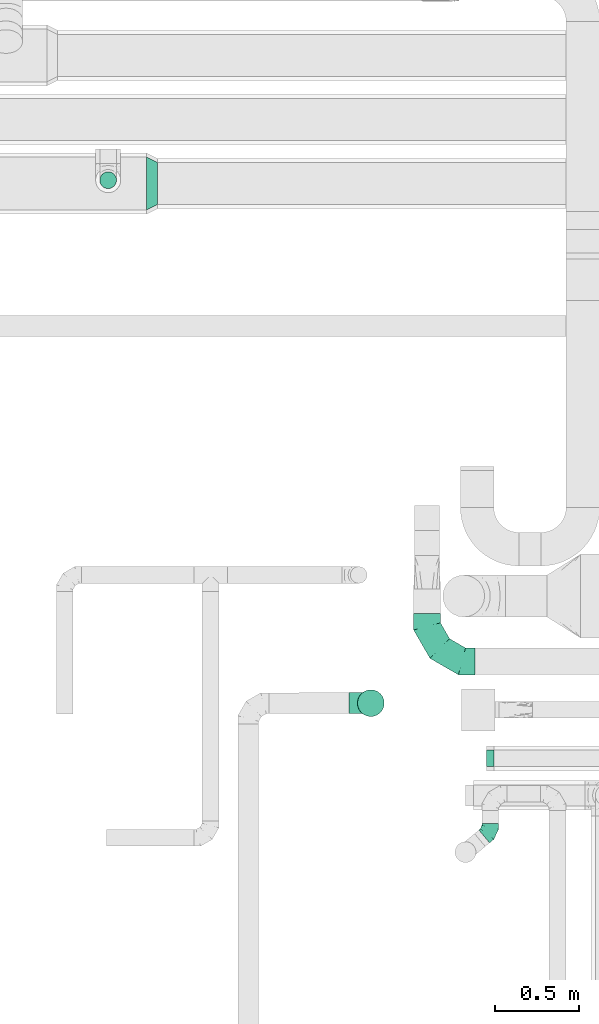
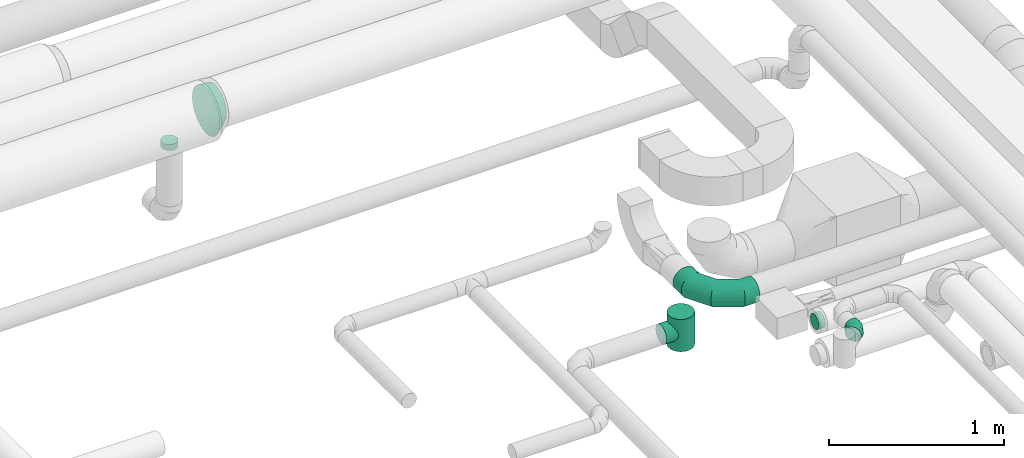
# One storey, part 90 of 92: 6 flow fittings.
"""IFC2X3 building model written with IfcOpenShell, lengths in millimetres."""

import ifcopenshell
import ifcopenshell.guid

model = None  # the IFC model being written
_history = None  # IfcOwnerHistory: only IFC2X3 demands one
_inside = {}  # id of a spatial element -> (the spatial element, [elements in it])
_under = {}  # id of a project, library or spatial element -> (it, [spatial elements below it])
_declared = {}  # id of a project -> (the project, [libraries it declares])
_typed = {}  # id of a type object -> (the type object, [elements of that type])
_made_of = {}  # id of a material, layer set ... -> (it, [elements and type objects made of it])


def new_model(schema):
    """Start an empty IFC model of exactly this schema.

    Asked for "IFC4X3", IfcOpenShell would pick the latest addendum, in which some entities
    have other attributes; the version numbers below select the first issue.
    IFC2X3 requires an IfcOwnerHistory on every rooted entity: one is made here for all.
    """
    global model, _history
    if schema == "IFC4X3":
        model = ifcopenshell.file(schema_version=(4, 3, 0, 0))
    else:
        model = ifcopenshell.file(schema=schema)
    _inside.clear()
    _under.clear()
    _declared.clear()
    _typed.clear()
    _made_of.clear()
    _history = None
    if model.schema == "IFC2X3":
        org = make("IfcOrganization", Name="unknown")
        user = make(
            "IfcPersonAndOrganization",
            ThePerson=make("IfcPerson", FamilyName="unknown"),
            TheOrganization=org,
        )
        app = make(
            "IfcApplication",
            ApplicationDeveloper=org,
            Version="unknown",
            ApplicationFullName="unknown",
            ApplicationIdentifier="unknown",
        )
        _history = make(
            "IfcOwnerHistory",
            OwningUser=user,
            OwningApplication=app,
            ChangeAction="ADDED",
            CreationDate=0,
        )
    return model


def make(cls, **values):
    """One entity of the class cls with the attributes given. An attribute that is None is left unset."""
    return model.create_entity(
        cls, **{name: value for name, value in values.items() if value is not None}
    )


def entity(cls, *values):
    """Any entity or typed value of the class cls, its attributes in the order of the schema. None: left unset."""
    e = model.create_entity(cls)
    for i, value in enumerate(values):
        if value is not None:
            e[i] = value
    return e


def rooted(cls, **values):
    """An entity with a GlobalId (a new one), such as an element, a storey or a relation."""
    return make(cls, GlobalId=ifcopenshell.guid.new(), OwnerHistory=_history, **values)


def si_unit(unit_type, name, prefix=None):
    """IfcSIUnit, for example si_unit("LENGTHUNIT", "METRE", prefix="MILLI")."""
    return make("IfcSIUnit", UnitType=unit_type, Prefix=prefix, Name=name)


def converted_unit(unit_type, name, factor, base, dimensions=None, offset=None):
    """IfcConversionBasedUnit, such as the inch: factor (a typed value) times the base unit."""
    return make(
        "IfcConversionBasedUnit"
        if offset is None
        else "IfcConversionBasedUnitWithOffset",
        ConversionOffset=offset,
        Dimensions=None
        if dimensions is None
        else entity("IfcDimensionalExponents", *dimensions),
        UnitType=unit_type,
        Name=name,
        ConversionFactor=make(
            "IfcMeasureWithUnit", ValueComponent=factor, UnitComponent=base
        ),
    )


def derived_unit(unit_type, elements):
    """IfcDerivedUnit: a product of units, each with its exponent."""
    return make(
        "IfcDerivedUnit",
        Elements=[
            make("IfcDerivedUnitElement", Unit=unit, Exponent=power)
            for unit, power in elements
        ],
        UnitType=unit_type,
    )


def assignment(units):
    """IfcUnitAssignment: the units of a project."""
    return None if units is None else make("IfcUnitAssignment", Units=units)


def point(xyz):
    """IfcCartesianPoint."""
    return None if xyz is None else make("IfcCartesianPoint", Coordinates=xyz)


def direction(xyz):
    """IfcDirection."""
    return None if xyz is None else make("IfcDirection", DirectionRatios=xyz)


def frame(location, z_axis=None, x_axis=None):
    """IfcAxis2Placement3D, a coordinate frame: its origin and axes. An axis left out is left unset."""
    return make(
        "IfcAxis2Placement3D",
        Location=point(location),
        Axis=direction(z_axis),
        RefDirection=direction(x_axis),
    )


def origin():
    """The frame at (0, 0, 0) with its axes left unset."""
    return frame((0.0, 0.0, 0.0))


def place(relative_to, where):
    """IfcLocalPlacement: puts the frame where relative to a parent placement (None: the world)."""
    return make(
        "IfcLocalPlacement", PlacementRelTo=relative_to, RelativePlacement=where
    )


def context(
    kind, dimensions, precision=None, world=None, true_north=None, identifier=None
):
    """IfcGeometricRepresentationContext, for example the 3D "Model" context."""
    return make(
        "IfcGeometricRepresentationContext",
        ContextIdentifier=identifier,
        ContextType=kind,
        CoordinateSpaceDimension=dimensions,
        Precision=precision,
        WorldCoordinateSystem=world,
        TrueNorth=true_north,
    )


def subcontext(parent, identifier, kind, view, scale=None):
    """IfcGeometricRepresentationSubContext, for example "Body" below "Model"."""
    return make(
        "IfcGeometricRepresentationSubContext",
        ContextIdentifier=identifier,
        ContextType=kind,
        ParentContext=parent,
        TargetScale=scale,
        TargetView=view,
    )


def project(units=None, contexts=None):
    """IfcProject with its units and contexts."""
    return rooted(
        "IfcProject",
        Name="project",
        RepresentationContexts=contexts,
        UnitsInContext=assignment(units),
    )


def spatial(cls, under=None, at=None, **own):
    """A site, building, storey or space (cls), placed at a placement, below another one or the project."""
    s = rooted(cls, ObjectPlacement=at, **own)
    if under is not None:
        _under.setdefault(under.id(), (under, []))[1].append(s)
    return s


def faces_of(points, faces, orient=None, outer=None):
    """IfcFace entities. A face is a list of loops; a loop is a list of indices into points, from 0.

    orient and outer hold one flag for each loop. By default every Orientation is true, the
    first loop of a face is its IfcFaceOuterBound and the others are IfcFaceBound.
    """
    made = []
    for i, loops in enumerate(faces):
        bounds = []
        for j, loop in enumerate(loops):
            is_outer = j == 0 if outer is None else outer[i][j]
            bounds.append(
                make(
                    "IfcFaceOuterBound" if is_outer else "IfcFaceBound",
                    Bound=make("IfcPolyLoop", Polygon=[points[k] for k in loop]),
                    Orientation=True if orient is None else orient[i][j],
                )
            )
        made.append(make("IfcFace", Bounds=bounds))
    return made


def faceted_brep(points, faces, orient=None, outer=None, voids=None):
    """IfcFacetedBrep: a solid bounded by flat faces; with voids (closed shells), ...WithVoids."""
    shared = [point(p) for p in points]
    hull = make("IfcClosedShell", CfsFaces=faces_of(shared, faces, orient, outer))
    if voids is None:
        return make("IfcFacetedBrep", Outer=hull)
    return make(
        "IfcFacetedBrepWithVoids",
        Outer=hull,
        Voids=[
            make(cls, CfsFaces=faces_of(shared, fs, o, b)) for cls, fs, o, b in voids
        ],
    )


def shape(context_of_items, identifier, shape_type, items):
    """IfcShapeRepresentation: the items that make up one representation, for example the "Body"."""
    return make(
        "IfcShapeRepresentation",
        ContextOfItems=context_of_items,
        RepresentationIdentifier=identifier,
        RepresentationType=shape_type,
        Items=items,
    )


def source(mapping_origin, context_of_items, identifier, shape_type, items):
    """IfcRepresentationMap: a shape defined once, which mapped items show again and again."""
    return make(
        "IfcRepresentationMap",
        MappingOrigin=mapping_origin,
        MappedRepresentation=shape(context_of_items, identifier, shape_type, items),
    )


def transform(
    local_origin,
    x_axis=None,
    y_axis=None,
    z_axis=None,
    scale=None,
    scale2=None,
    scale3=None,
    uniform=True,
):
    """IfcCartesianTransformationOperator3D, or its non-uniform kind. x_axis, y_axis, z_axis: its Axis1, 2, 3."""
    if uniform:
        return make(
            "IfcCartesianTransformationOperator3D",
            Axis1=direction(x_axis),
            Axis2=direction(y_axis),
            LocalOrigin=point(local_origin),
            Scale=scale,
            Axis3=direction(z_axis),
        )
    return make(
        "IfcCartesianTransformationOperator3DnonUniform",
        Axis1=direction(x_axis),
        Axis2=direction(y_axis),
        LocalOrigin=point(local_origin),
        Scale=scale,
        Axis3=direction(z_axis),
        Scale2=scale2,
        Scale3=scale3,
    )


def mapped(mapping_source, mapping_target):
    """IfcMappedItem: shows the shape of a source again, moved by a transform."""
    return make(
        "IfcMappedItem", MappingSource=mapping_source, MappingTarget=mapping_target
    )


def material(Name=None, Category=None):
    """IfcMaterial."""
    return make("IfcMaterial", Name=Name, Category=Category)


def made_of(thing, what):
    """Note that an element or type object is made of a material, layer set ...; save() writes the relation."""
    if what is not None:
        _made_of.setdefault(what.id(), (what, []))[1].append(thing)
    return thing


def type_object(cls, material=None, **own):
    """A type object (cls), such as IfcWallType, which elements share."""
    return made_of(rooted(cls, **own), material)


def type_shapes(of_type, sources):
    """Give a type object the sources (RepresentationMaps) that its elements show as mapped items."""
    of_type.RepresentationMaps = sources


def element(
    cls,
    number,
    at=None,
    inside=None,
    cuts=None,
    type_object=None,
    material=None,
    context=None,
    identifier="Body",
    shape_type=None,
    held_by="IfcProductDefinitionShape",
    body=None,
    shapes=None,
    **own,
):
    """One element of the class cls, such as IfcWall. Its Tag is "e" and its number.

    at: its placement. inside: the storey or other place that contains it. cuts: it is an
    opening in that element (IfcRelVoidsElement). A single representation is given by context,
    identifier, shape_type and body (its items); several are given by shapes. held_by: the class
    of the entity that holds the representations. save() writes the other relations.
    """
    e = rooted(cls, Tag="e%d" % number, ObjectPlacement=at, **own)
    if body is not None:
        shapes = [shape(context, identifier, shape_type, body)]
    if shapes is not None:
        e.Representation = make(held_by, Representations=shapes)
    if inside is not None:
        _inside.setdefault(inside.id(), (inside, []))[1].append(e)
    if cuts is not None:
        rooted(
            "IfcRelVoidsElement", RelatingBuildingElement=cuts, RelatedOpeningElement=e
        )
    if type_object is not None:
        _typed.setdefault(type_object.id(), (type_object, []))[1].append(e)
    return made_of(e, material)


def aggregate(whole, parts):
    """IfcRelAggregates: a whole, such as a stair, and the parts it consists of."""
    return rooted("IfcRelAggregates", RelatingObject=whole, RelatedObjects=parts)


def save(model, path):
    """Write the relations noted so far, then the file.

    IfcRelAggregates (storeys below a building ...), IfcRelContainedInSpatialStructure (elements
    in a storey), IfcRelDefinesByType, IfcRelAssociatesMaterial and IfcRelDeclares: one each for
    every whole, place, type object, material and project.
    """
    for whole, parts in _under.values():
        aggregate(whole, parts)
    for where, things in _inside.values():
        rooted(
            "IfcRelContainedInSpatialStructure",
            RelatedElements=things,
            RelatingStructure=where,
        )
    for kind, things in _typed.values():
        rooted("IfcRelDefinesByType", RelatedObjects=things, RelatingType=kind)
    for what, things in _made_of.values():
        rooted("IfcRelAssociatesMaterial", RelatedObjects=things, RelatingMaterial=what)
    for by, libraries in _declared.values():
        rooted("IfcRelDeclares", RelatingContext=by, RelatedDefinitions=libraries)
    model.write(path)


model = new_model("IFC2X3")

# Units and contexts
model_context = context("Model", 3, precision=0.01, world=origin(), true_north=direction((6.12303176911189e-17, 1.0)))
body_context = subcontext(model_context, "Body", "Model", "MODEL_VIEW")
ifc_project = project(units=[si_unit("LENGTHUNIT", "METRE", prefix="MILLI"), si_unit("AREAUNIT", "SQUARE_METRE"), si_unit("VOLUMEUNIT", "CUBIC_METRE"), converted_unit("PLANEANGLEUNIT", "DEGREE", entity("IfcRatioMeasure", 0.0174532925199433), si_unit("PLANEANGLEUNIT", "RADIAN"), dimensions=[0, 0, 0, 0, 0, 0, 0]), si_unit("MASSUNIT", "GRAM", prefix="KILO"), derived_unit("MASSDENSITYUNIT", [(si_unit("MASSUNIT", "GRAM", prefix="KILO"), 1), (si_unit("LENGTHUNIT", "METRE"), -3)]), derived_unit("MOMENTOFINERTIAUNIT", [(si_unit("LENGTHUNIT", "METRE"), 4)]), si_unit("TIMEUNIT", "SECOND"), si_unit("FREQUENCYUNIT", "HERTZ"), si_unit("THERMODYNAMICTEMPERATUREUNIT", "DEGREE_CELSIUS"), derived_unit("THERMALTRANSMITTANCEUNIT", [(si_unit("MASSUNIT", "GRAM", prefix="KILO"), 1), (si_unit("THERMODYNAMICTEMPERATUREUNIT", "KELVIN"), -1), (si_unit("TIMEUNIT", "SECOND"), -3)]), derived_unit("VOLUMETRICFLOWRATEUNIT", [(si_unit("LENGTHUNIT", "METRE"), 3), (si_unit("TIMEUNIT", "SECOND"), -1)]), derived_unit("MASSFLOWRATEUNIT", [(si_unit("MASSUNIT", "GRAM", prefix="KILO"), 1), (si_unit("TIMEUNIT", "SECOND"), -1)]), derived_unit("ROTATIONALFREQUENCYUNIT", [(si_unit("TIMEUNIT", "SECOND"), -1)]), si_unit("ELECTRICCURRENTUNIT", "AMPERE"), si_unit("ELECTRICVOLTAGEUNIT", "VOLT"), si_unit("POWERUNIT", "WATT"), si_unit("FORCEUNIT", "NEWTON", prefix="KILO"), si_unit("ILLUMINANCEUNIT", "LUX"), si_unit("LUMINOUSFLUXUNIT", "LUMEN"), si_unit("LUMINOUSINTENSITYUNIT", "CANDELA"), derived_unit("USERDEFINED", [(si_unit("MASSUNIT", "GRAM", prefix="KILO"), -1), (si_unit("LENGTHUNIT", "METRE"), -2), (si_unit("TIMEUNIT", "SECOND"), 3), (si_unit("LUMINOUSFLUXUNIT", "LUMEN"), 1)]), derived_unit("LINEARVELOCITYUNIT", [(si_unit("LENGTHUNIT", "METRE"), 1), (si_unit("TIMEUNIT", "SECOND"), -1)]), si_unit("PRESSUREUNIT", "PASCAL"), derived_unit("USERDEFINED", [(si_unit("LENGTHUNIT", "METRE"), -2), (si_unit("MASSUNIT", "GRAM", prefix="KILO"), 1), (si_unit("TIMEUNIT", "SECOND"), -2)]), derived_unit("LINEARFORCEUNIT", [(si_unit("MASSUNIT", "GRAM", prefix="KILO"), 1), (si_unit("LENGTHUNIT", "METRE"), 1), (si_unit("TIMEUNIT", "SECOND"), -2), (si_unit("LENGTHUNIT", "METRE"), -1)]), derived_unit("PLANARFORCEUNIT", [(si_unit("MASSUNIT", "GRAM", prefix="KILO"), 1), (si_unit("LENGTHUNIT", "METRE"), 1), (si_unit("TIMEUNIT", "SECOND"), -2), (si_unit("LENGTHUNIT", "METRE"), -2)])], contexts=[model_context])

# Site, building, storey
site_placement = place(None, origin())
site = spatial("IfcSite", under=ifc_project, at=site_placement, CompositionType="ELEMENT")
building_placement = place(site_placement, origin())
building = spatial("IfcBuilding", under=site, at=building_placement, CompositionType="ELEMENT")
storey_placement = place(building_placement, frame((0.0, 0.0, 4200.0)))
storey = spatial("IfcBuildingStorey", under=building, at=storey_placement, CompositionType="ELEMENT", Elevation=4200.0)

# Flow fittings
ifc_material = material()
duct_fitting_type_1 = type_object("IfcDuctFittingType", PredefinedType="NOTDEFINED", material=ifc_material)
shared_shape_1 = source(origin(), body_context, "Body", "Brep", [
    faceted_brep([(16.18, -130.0, -60.37), (31.25, -130.0, -54.13), (44.19, -130.0, -44.19), (54.13, -130.0, -31.25), (60.37, -130.0, -16.18), (62.5, -130.0, 0.0), (60.37, -130.0, 16.18), (54.13, -130.0, 31.25), (44.19, -130.0, 44.19), (31.25, -130.0, 54.13), (16.18, -130.0, 60.37), (0.0, -130.0, 62.5), (-16.18, -130.0, 60.37), (-31.25, -130.0, 54.13), (-44.19, -130.0, 44.19), (-54.13, -130.0, 31.25), (-60.37, -130.0, 16.18), (-62.5, -130.0, 0.0), (-60.37, -130.0, -16.18), (-54.13, -130.0, -31.25), (-44.19, -130.0, -44.19), (-31.25, -130.0, -54.13), (-16.18, -130.0, -60.37), (0.0, -130.0, -62.5), (12.74, -51.54, 61.19), (24.44, -55.6, 57.52), (34.82, -60.88, 51.9), (43.86, -66.46, 44.53), (0.0, -49.94, 62.5), (51.46, -71.71, 35.47), (57.36, -76.05, 24.81), (61.17, -78.97, 12.81), (62.5, -80.0, 0.0), (61.17, -78.97, -12.81), (51.46, -71.71, -35.47), (57.36, -76.05, -24.81), (43.86, -66.46, -44.52), (34.82, -60.88, -51.9), (24.44, -55.6, -57.52), (12.73, -51.53, -61.19), (0.0, -49.94, -62.5), (-12.74, -51.54, -61.19), (-24.44, -55.6, -57.52), (-34.82, -60.88, -51.9), (-43.86, -66.46, -44.53), (-51.46, -71.71, -35.47), (-57.36, -76.05, -24.81), (-61.17, -78.97, -12.81), (-62.5, -80.0, 0.0), (-61.17, -78.97, 12.81), (-57.36, -76.05, 24.81), (-51.46, -71.71, 35.47), (-43.86, -66.46, 44.53), (-34.82, -60.88, 51.9), (-24.44, -55.6, 57.52), (-12.74, -51.54, 61.19), (-112.5, 0.0, -80.0), (-112.5, -20.71, -77.27), (-112.5, -40.0, -69.28), (-112.5, -56.57, -56.57), (-112.5, -62.93, -48.28), (-112.5, -69.28, -40.0), (-112.5, -73.28, -30.35), (-112.5, -77.27, -20.71), (-112.5, -78.64, -10.35), (-112.5, -80.0, 0.0), (-112.5, -78.64, 10.35), (-112.5, -77.27, 20.71), (-112.5, -73.28, 30.35), (-112.5, -69.28, 40.0), (-112.5, -62.93, 48.28), (-112.5, -56.57, 56.57), (-112.5, -40.0, 69.28), (-112.5, -20.71, 77.27), (-112.5, 0.0, 80.0), (-112.5, 20.71, 77.27), (-112.5, 40.0, 69.28), (-112.5, 56.57, 56.57), (-112.5, 69.28, 40.0), (-112.5, 77.27, 20.71), (-112.5, 80.0, 0.0), (-112.5, 77.27, -20.71), (-112.5, 69.28, -40.0), (-112.5, 56.57, -56.57), (-112.5, 40.0, -69.28), (-112.5, 20.71, -77.27), (112.5, 20.71, -77.27), (112.5, 40.0, -69.28), (112.5, 56.57, -56.57), (112.5, 69.28, -40.0), (112.5, 77.27, -20.71), (112.5, 80.0, 0.0), (112.5, 77.27, 20.71), (112.5, 69.28, 40.0), (112.5, 56.57, 56.57), (112.5, 40.0, 69.28), (112.5, 20.71, 77.27), (112.5, 0.0, 80.0), (112.5, -20.71, 77.27), (112.5, -40.0, 69.28), (112.5, -56.57, 56.57), (112.5, -62.93, 48.28), (112.5, -69.28, 40.0), (112.5, -73.28, 30.35), (112.5, -77.27, 20.71), (112.5, -78.64, 10.35), (112.5, -80.0, 0.0), (112.5, -78.64, -10.35), (112.5, -77.27, -20.71), (112.5, -73.28, -30.35), (112.5, -69.28, -40.0), (112.5, -62.93, -48.28), (112.5, -56.57, -56.57), (112.5, -40.0, -69.28), (112.5, -20.71, -77.27), (112.5, 0.0, -80.0)], [[[0, 1, 2, 3, 4, 5, 6, 7, 8, 9, 10, 11, 12, 13, 14, 15, 16, 17, 18, 19, 20, 21, 22, 23]], [[24, 11, 10]], [[10, 9, 25]], [[8, 26, 9]], [[8, 27, 26]], [[28, 11, 24]], [[24, 10, 25]], [[9, 26, 25]], [[29, 8, 7]], [[30, 7, 6]], [[31, 6, 5]], [[30, 29, 7]], [[32, 31, 5]], [[30, 6, 31]], [[8, 29, 27]], [[5, 4, 33]], [[3, 2, 34]], [[4, 3, 35]], [[33, 32, 5]], [[34, 35, 3]], [[33, 4, 35]], [[2, 36, 34]], [[36, 2, 37]], [[37, 2, 1]], [[38, 1, 0]], [[39, 0, 23]], [[37, 1, 38]], [[39, 38, 0]], [[40, 39, 23]], [[41, 23, 22]], [[22, 21, 42]], [[20, 43, 21]], [[20, 44, 43]], [[40, 23, 41]], [[41, 22, 42]], [[21, 43, 42]], [[45, 20, 19]], [[46, 19, 18]], [[47, 18, 17]], [[46, 45, 19]], [[48, 47, 17]], [[46, 18, 47]], [[20, 45, 44]], [[49, 17, 16]], [[50, 16, 15]], [[51, 15, 14]], [[49, 48, 17]], [[51, 50, 15]], [[49, 16, 50]], [[14, 52, 51]], [[52, 14, 53]], [[53, 14, 13]], [[54, 13, 12]], [[55, 12, 11]], [[53, 13, 54]], [[55, 54, 12]], [[28, 55, 11]], [[56, 57, 58, 59, 60, 61, 62, 63, 64, 65, 66, 67, 68, 69, 70, 71, 72, 73, 74, 75, 76, 77, 78, 79, 80, 81, 82, 83, 84, 85]], [[86, 87, 88, 89, 90, 91, 92, 93, 94, 95, 96, 97, 98, 99, 100, 101, 102, 103, 104, 105, 106, 107, 108, 109, 110, 111, 112, 113, 114, 115]], [[75, 74, 97, 96]], [[76, 75, 96, 95]], [[95, 94, 77, 76]], [[79, 78, 93, 92]], [[80, 79, 92, 91]], [[94, 93, 78, 77]], [[81, 80, 91, 90]], [[82, 81, 90, 89]], [[89, 88, 83, 82]], [[85, 84, 87, 86]], [[56, 85, 86, 115]], [[88, 87, 84, 83]], [[114, 57, 56, 115]], [[113, 58, 57, 114]], [[112, 37, 38]], [[112, 111, 37]], [[46, 63, 62]], [[38, 39, 112]], [[34, 109, 35]], [[112, 39, 113]], [[39, 40, 113]], [[113, 40, 58]], [[40, 41, 58]], [[41, 42, 59]], [[48, 64, 47]], [[43, 44, 60]], [[43, 59, 42]], [[44, 61, 60]], [[41, 59, 58]], [[37, 111, 36]], [[33, 108, 107]], [[109, 34, 110]], [[35, 109, 108]], [[34, 36, 110]], [[110, 36, 111]], [[106, 32, 107]], [[48, 65, 64]], [[33, 107, 32]], [[108, 33, 35]], [[44, 45, 61]], [[45, 62, 61]], [[62, 45, 46]], [[60, 59, 43]], [[64, 63, 47]], [[47, 63, 46]], [[106, 105, 32]], [[65, 48, 66]], [[31, 105, 104]], [[102, 29, 103]], [[30, 103, 29]], [[104, 30, 31]], [[49, 66, 48]], [[49, 50, 67]], [[51, 52, 69]], [[50, 68, 67]], [[68, 51, 69]], [[52, 70, 69]], [[29, 102, 27]], [[101, 26, 27]], [[26, 101, 100]], [[27, 102, 101]], [[25, 26, 100]], [[100, 24, 25]], [[32, 105, 31]], [[73, 72, 99, 98]], [[28, 24, 99]], [[99, 24, 100]], [[98, 97, 74, 73]], [[51, 68, 50]], [[54, 55, 71]], [[49, 67, 66]], [[70, 53, 71]], [[71, 53, 54]], [[55, 72, 71]], [[30, 104, 103]], [[28, 72, 55]], [[28, 99, 72]], [[53, 70, 52]]]),
])
type_shapes(duct_fitting_type_1, [shared_shape_1])
flow_fitting_1_placement = place(storey_placement, frame((58915.63, 11854.23, 3150.0), z_axis=(0.0, -1.0, 0.0), x_axis=(0.0, 0.0, -1.0)))
element("IfcFlowFitting", 1, at=flow_fitting_1_placement, inside=storey, type_object=duct_fitting_type_1, material=ifc_material, context=body_context, shape_type="MappedRepresentation", body=[
    mapped(shared_shape_1, transform((0.0, 0.0, 0.0), scale=1.0)),
])
duct_fitting_type_2 = type_object("IfcDuctFittingType", PredefinedType="NOTDEFINED", material=ifc_material)
shared_shape_2 = source(origin(), body_context, "Body", "Brep", [
    faceted_brep([(-46.66, 0.0, -50.0), (-46.66, -12.94, -48.3), (-46.66, -25.0, -43.3), (-46.66, -35.36, -35.36), (-46.66, -43.3, -25.0), (-46.66, -48.3, -12.94), (-46.66, -50.0, 0.0), (-46.66, -48.3, 12.94), (-46.66, -43.3, 25.0), (-46.66, -35.36, 35.36), (-46.66, -25.0, 43.3), (-46.66, -12.94, 48.3), (-46.66, 0.0, 50.0), (-46.66, 12.94, 48.3), (-46.66, 25.0, 43.3), (-46.66, 35.36, 35.36), (-46.66, 43.3, 25.0), (-46.66, 48.3, 12.94), (-46.66, 50.0, 0.0), (-46.66, 48.3, -12.94), (-46.66, 43.3, -25.0), (-46.66, 35.36, -35.36), (-46.66, 25.0, -43.3), (-46.66, 12.94, -48.3), (-27.35, 12.94, 48.3), (-30.02, 25.0, 43.3), (-24.48, 0.0, 50.0), (-32.32, 35.36, 35.36), (-35.19, 48.3, 12.94), (-35.57, 50.0, 0.0), (-34.08, 43.3, 25.0), (-34.08, 43.3, -25.0), (-32.32, 35.36, -35.36), (-35.19, 48.3, -12.94), (-27.35, 12.94, -48.3), (-24.48, 0.0, -50.0), (-30.02, 25.0, -43.3), (-21.61, -12.94, -48.3), (-18.93, -25.0, -43.3), (-16.63, -35.36, -35.36), (-14.87, -43.3, -25.0), (-13.76, -48.3, -12.94), (-13.39, -50.0, 0.0), (-13.76, -48.3, 12.94), (-14.87, -43.3, 25.0), (-16.63, -35.36, 35.36), (-18.93, -25.0, 43.3), (-21.61, -12.94, 48.3), (7.65, 29.27, 48.3), (0.13, 39.07, 43.3), (15.72, 18.76, 50.0), (-6.33, 47.48, 35.36), (-11.29, 53.94, 25.0), (-14.4, 57.99, 12.94), (-15.47, 59.38, 0.0), (-14.4, 57.99, -12.94), (-11.29, 53.94, -25.0), (-6.33, 47.48, -35.36), (7.65, 29.27, -48.3), (15.72, 18.76, -50.0), (0.13, 39.07, -43.3), (23.8, 8.24, -48.3), (31.32, -1.55, -43.3), (37.78, -9.97, -35.36), (42.74, -16.42, -25.0), (45.85, -20.48, -12.94), (46.92, -21.86, 0.0), (45.85, -20.48, 12.94), (42.74, -16.42, 25.0), (37.78, -9.97, 35.36), (31.32, -1.55, 43.3), (23.8, 8.24, 48.3), (29.98, 35.75, 50.0), (20.06, 44.07, 48.3), (10.82, 51.82, 43.3), (2.88, 58.47, 35.36), (-3.21, 63.57, 25.0), (-7.04, 66.78, 12.94), (-8.34, 67.88, 0.0), (-7.04, 66.78, -12.94), (-3.21, 63.57, -25.0), (2.88, 58.47, -35.36), (20.06, 44.07, -48.3), (29.98, 35.75, -50.0), (10.82, 51.82, -43.3), (39.89, 27.44, -48.3), (49.13, 19.69, -43.3), (57.07, 13.04, -35.36), (66.99, 4.73, -12.94), (68.29, 3.63, 0.0), (63.16, 7.94, -25.0), (66.99, 4.73, 12.94), (63.16, 7.94, 25.0), (57.07, 13.04, 35.36), (49.13, 19.69, 43.3), (39.89, 27.44, 48.3)], [[[0, 1, 2, 3, 4, 5, 6, 7, 8, 9, 10, 11, 12, 13, 14, 15, 16, 17, 18, 19, 20, 21, 22, 23]], [[24, 25, 14, 13]], [[26, 24, 13, 12]], [[14, 25, 27, 15]], [[28, 29, 18, 17]], [[30, 28, 17, 16]], [[15, 27, 30, 16]], [[20, 31, 32, 21]], [[33, 31, 20, 19]], [[18, 29, 33, 19]], [[34, 35, 0, 23]], [[36, 34, 23, 22]], [[32, 36, 22, 21]], [[2, 1, 37, 38]], [[3, 2, 38, 39]], [[0, 35, 37, 1]], [[5, 4, 40, 41]], [[6, 5, 41, 42]], [[39, 40, 4, 3]], [[6, 42, 43, 7]], [[7, 43, 44, 8]], [[8, 44, 45, 9]], [[10, 46, 47, 11]], [[11, 47, 26, 12]], [[9, 45, 46, 10]], [[48, 49, 25, 24]], [[50, 48, 24, 26]], [[51, 27, 25, 49]], [[52, 53, 28, 30]], [[51, 52, 30, 27]], [[29, 28, 53, 54]], [[55, 56, 31, 33]], [[54, 55, 33, 29]], [[32, 31, 56, 57]], [[58, 59, 35, 34]], [[60, 58, 34, 36]], [[57, 60, 36, 32]], [[37, 35, 59, 61]], [[38, 37, 61, 62]], [[39, 38, 62, 63]], [[41, 40, 64, 65]], [[42, 41, 65, 66]], [[63, 64, 40, 39]], [[43, 42, 66, 67]], [[44, 43, 67, 68]], [[68, 69, 45, 44]], [[46, 45, 69, 70]], [[47, 46, 70, 71]], [[26, 47, 71, 50]], [[48, 50, 72, 73]], [[49, 48, 73, 74]], [[51, 49, 74, 75]], [[53, 52, 76, 77]], [[54, 53, 77, 78]], [[51, 75, 76, 52]], [[54, 78, 79, 55]], [[55, 79, 80, 56]], [[56, 80, 81, 57]], [[82, 83, 59, 58]], [[84, 82, 58, 60]], [[60, 57, 81, 84]], [[59, 83, 85, 61]], [[61, 85, 86, 62]], [[62, 86, 87, 63]], [[88, 89, 66, 65]], [[90, 88, 65, 64]], [[63, 87, 90, 64]], [[67, 66, 89, 91]], [[68, 67, 91, 92]], [[69, 68, 92, 93]], [[71, 70, 94, 95]], [[50, 71, 95, 72]], [[93, 94, 70, 69]], [[82, 84, 81, 80, 79, 78, 77, 76, 75, 74, 73, 72, 95, 94, 93, 92, 91, 89, 88, 90, 87, 86, 85, 83]]]),
])
type_shapes(duct_fitting_type_2, [shared_shape_2])
flow_fitting_2_placement = place(storey_placement, frame((59628.25, 11088.45, 3350.0), z_axis=(0.0, 0.0, 1.0), x_axis=(0.766326560722248, 0.642451245100833, 0.0)))
element("IfcFlowFitting", 2, at=flow_fitting_2_placement, inside=storey, type_object=duct_fitting_type_2, material=ifc_material, context=body_context, shape_type="MappedRepresentation", body=[
    mapped(shared_shape_2, transform((0.0, 0.0, 0.0), scale=1.0)),
])
duct_fitting_type_3 = type_object("IfcDuctFittingType", PredefinedType="NOTDEFINED", material=ifc_material)
shared_shape_3 = source(origin(), body_context, "Body", "Brep", [
    faceted_brep([(-284.98, 0.0, -80.0), (-284.98, -20.71, -77.27), (-284.98, -40.0, -69.28), (-284.98, -56.57, -56.57), (-284.98, -69.28, -40.0), (-284.98, -77.27, -20.71), (-284.98, -80.0, 0.0), (-284.98, -77.27, 20.71), (-284.98, -69.28, 40.0), (-284.98, -56.57, 56.57), (-284.98, -40.0, 69.28), (-284.98, -20.71, 77.27), (-284.98, 0.0, 80.0), (-284.98, 20.71, 77.27), (-284.98, 40.0, 69.28), (-284.98, 56.57, 56.57), (-284.98, 69.28, 40.0), (-284.98, 77.27, 20.71), (-284.98, 80.0, 0.0), (-284.98, 77.27, -20.71), (-284.98, 69.28, -40.0), (-284.98, 56.57, -56.57), (-284.98, 40.0, -69.28), (-284.98, 20.71, -77.27), (-214.16, 20.71, 77.27), (-219.33, 40.0, 69.28), (-208.62, 0.0, 80.0), (-223.77, 56.57, 56.57), (-227.18, 69.28, 40.0), (-229.32, 77.27, 20.71), (-230.05, 80.0, 0.0), (-229.32, 77.27, -20.71), (-227.18, 69.28, -40.0), (-223.77, 56.57, -56.57), (-214.16, 20.71, -77.27), (-208.62, 0.0, -80.0), (-219.33, 40.0, -69.28), (-203.07, -20.71, -77.27), (-197.9, -40.0, -69.28), (-193.46, -56.57, -56.57), (-190.05, -69.28, -40.0), (-187.91, -77.27, -20.71), (-187.18, -80.0, 0.0), (-187.91, -77.27, 20.71), (-190.05, -69.28, 40.0), (-193.46, -56.57, 56.57), (-197.9, -40.0, 69.28), (-203.07, -20.71, 77.27), (-20.68, 284.98, -77.27), (-39.98, 284.98, -69.28), (-56.55, 284.98, -56.57), (-69.26, 284.98, -40.0), (-77.25, 284.98, -20.71), (-79.98, 284.98, 0.0), (-77.25, 284.98, 20.71), (-69.26, 284.98, 40.0), (-56.55, 284.98, 56.57), (-39.98, 284.98, 69.28), (-20.68, 284.98, 77.27), (0.02, 284.98, 80.0), (20.73, 284.98, 77.27), (40.02, 284.97, 69.28), (56.59, 284.97, 56.57), (69.31, 284.97, 40.0), (77.3, 284.97, 20.71), (80.02, 284.97, 0.0), (77.3, 284.97, -20.71), (69.31, 284.97, -40.0), (56.59, 284.97, -56.57), (40.02, 284.97, -69.28), (20.73, 284.98, -77.27), (0.02, 284.98, -80.0), (-91.51, 91.52, 77.27), (-105.63, 105.64, 69.28), (-76.35, 76.36, 80.0), (-117.76, 117.77, 56.57), (-127.07, 127.08, 40.0), (-132.92, 132.93, 20.71), (-134.91, 134.92, 0.0), (-132.92, 132.93, -20.71), (-127.07, 127.08, -40.0), (-117.76, 117.77, -56.57), (-91.51, 91.52, -77.27), (-76.35, 76.36, -80.0), (-105.63, 105.64, -69.28), (-61.19, 61.2, -77.27), (-47.07, 47.07, -69.28), (-34.94, 34.95, -56.57), (-25.64, 25.64, -40.0), (-19.79, 19.79, -20.71), (-17.79, 17.79, 0.0), (-19.79, 19.79, 20.71), (-25.64, 25.64, 40.0), (-34.94, 34.95, 56.57), (-47.07, 47.07, 69.28), (-61.19, 61.2, 77.27), (-20.69, 214.16, 77.27), (-39.98, 219.34, 69.28), (0.02, 208.62, 80.0), (-56.55, 223.78, 56.57), (-69.26, 227.18, 40.0), (-77.26, 229.33, 20.71), (-79.98, 230.06, 0.0), (-77.26, 229.33, -20.71), (-69.26, 227.18, -40.0), (-56.55, 223.78, -56.57), (-20.69, 214.16, -77.27), (0.02, 208.62, -80.0), (-39.98, 219.34, -69.28), (20.72, 203.07, -77.27), (40.02, 197.89, -69.28), (56.58, 193.45, -56.57), (69.3, 190.05, -40.0), (77.29, 187.9, -20.71), (80.02, 187.17, 0.0), (77.29, 187.9, 20.71), (69.3, 190.05, 40.0), (56.58, 193.45, 56.57), (40.02, 197.89, 69.28), (20.72, 203.07, 77.27)], [[[0, 1, 2, 3, 4, 5, 6, 7, 8, 9, 10, 11, 12, 13, 14, 15, 16, 17, 18, 19, 20, 21, 22, 23]], [[24, 25, 14, 13]], [[26, 24, 13, 12]], [[14, 25, 27, 15]], [[28, 29, 17, 16]], [[28, 16, 15, 27]], [[30, 18, 17, 29]], [[31, 32, 20, 19]], [[30, 31, 19, 18]], [[32, 33, 21, 20]], [[34, 35, 0, 23]], [[36, 34, 23, 22]], [[33, 36, 22, 21]], [[1, 0, 35, 37]], [[2, 1, 37, 38]], [[38, 39, 3, 2]], [[5, 4, 40, 41]], [[6, 5, 41, 42]], [[39, 40, 4, 3]], [[6, 42, 43, 7]], [[7, 43, 44, 8]], [[8, 44, 45, 9]], [[9, 45, 46, 10]], [[10, 46, 47, 11]], [[26, 12, 11, 47]], [[48, 49, 50, 51, 52, 53, 54, 55, 56, 57, 58, 59, 60, 61, 62, 63, 64, 65, 66, 67, 68, 69, 70, 71]], [[72, 73, 25, 24]], [[74, 72, 24, 26]], [[27, 25, 73, 75]], [[76, 77, 29, 28]], [[75, 76, 28, 27]], [[30, 29, 77, 78]], [[79, 80, 32, 31]], [[78, 79, 31, 30]], [[33, 32, 80, 81]], [[82, 83, 35, 34]], [[84, 82, 34, 36]], [[81, 84, 36, 33]], [[37, 35, 83, 85]], [[38, 37, 85, 86]], [[39, 38, 86, 87]], [[41, 40, 88, 89]], [[42, 41, 89, 90]], [[87, 88, 40, 39]], [[43, 42, 90, 91]], [[44, 43, 91, 92]], [[92, 93, 45, 44]], [[46, 45, 93, 94]], [[47, 46, 94, 95]], [[26, 47, 95, 74]], [[96, 97, 73, 72]], [[98, 96, 72, 74]], [[75, 73, 97, 99]], [[100, 101, 77, 76]], [[99, 100, 76, 75]], [[78, 77, 101, 102]], [[103, 104, 80, 79]], [[102, 103, 79, 78]], [[81, 80, 104, 105]], [[106, 107, 83, 82]], [[108, 106, 82, 84]], [[105, 108, 84, 81]], [[85, 83, 107, 109]], [[86, 85, 109, 110]], [[87, 86, 110, 111]], [[89, 88, 112, 113]], [[90, 89, 113, 114]], [[111, 112, 88, 87]], [[91, 90, 114, 115]], [[92, 91, 115, 116]], [[116, 117, 93, 92]], [[94, 93, 117, 118]], [[95, 94, 118, 119]], [[74, 95, 119, 98]], [[96, 98, 59, 58]], [[97, 96, 58, 57]], [[99, 97, 57, 56]], [[101, 100, 55, 54]], [[102, 101, 54, 53]], [[56, 55, 100, 99]], [[102, 53, 52, 103]], [[103, 52, 51, 104]], [[50, 105, 104, 51]], [[108, 49, 48, 106]], [[106, 48, 71, 107]], [[49, 108, 105, 50]], [[107, 71, 70, 109]], [[109, 70, 69, 110]], [[68, 111, 110, 69]], [[112, 67, 66, 113]], [[113, 66, 65, 114]], [[67, 112, 111, 68]], [[115, 114, 65, 64]], [[116, 115, 64, 63]], [[63, 62, 117, 116]], [[119, 118, 61, 60]], [[98, 119, 60, 59]], [[62, 61, 118, 117]]]),
])
type_shapes(duct_fitting_type_3, [shared_shape_3])
flow_fitting_3_placement = place(storey_placement, frame((59251.13, 12103.85, 3050.0), z_axis=(0.0, 0.0, 1.0), x_axis=(0.0, -1.0, 0.0)))
element("IfcFlowFitting", 3, at=flow_fitting_3_placement, inside=storey, type_object=duct_fitting_type_3, material=ifc_material, context=body_context, shape_type="MappedRepresentation", body=[
    mapped(shared_shape_3, transform((0.0, 0.0, 0.0), scale=1.0)),
])
duct_fitting_type_4 = type_object("IfcDuctFittingType", PredefinedType="NOTDEFINED", material=ifc_material)
shared_shape_4 = source(origin(), body_context, "Body", "Brep", [
    faceted_brep([(20.01, 12.94, -48.3), (20.01, 25.0, -43.3), (20.01, 35.36, -35.36), (20.01, 43.3, -25.0), (20.01, 48.3, -12.94), (20.01, 50.0, 0.0), (20.01, 48.3, 12.94), (20.01, 43.3, 25.0), (20.01, 35.36, 35.36), (20.01, 25.0, 43.3), (20.01, 12.94, 48.3), (20.01, 0.0, 50.0), (20.01, -12.94, 48.3), (20.01, -25.0, 43.3), (20.01, -35.36, 35.36), (20.01, -43.3, 25.0), (20.01, -48.3, 12.94), (20.01, -50.0, 0.0), (20.01, -48.3, -12.94), (20.01, -43.3, -25.0), (20.01, -35.36, -35.36), (20.01, -25.0, -43.3), (20.01, -12.94, -48.3), (20.01, 0.0, -50.0), (0.0, 0.0, 50.0), (0.0, 12.94, 48.3), (-23.65, 12.94, 48.3), (-23.65, 0.0, 50.0), (0.0, 25.0, 43.3), (-23.65, 25.0, 43.3), (0.0, 35.36, 35.36), (-23.65, 35.36, 35.36), (0.0, 43.3, 25.0), (0.0, 48.3, 12.94), (-23.65, 48.3, 12.94), (-23.65, 43.3, 25.0), (0.0, 50.0, 0.0), (-23.65, 50.0, 0.0), (0.0, 48.3, -12.94), (-23.65, 48.3, -12.94), (0.0, 43.3, -25.0), (-23.65, 43.3, -25.0), (0.0, 35.36, -35.36), (-23.65, 35.36, -35.36), (0.0, 25.0, -43.3), (0.0, 12.94, -48.3), (-23.65, 12.94, -48.3), (-23.65, 25.0, -43.3), (0.0, 0.0, -50.0), (-23.65, 0.0, -50.0), (0.0, -12.94, -48.3), (-23.65, -12.94, -48.3), (0.0, -25.0, -43.3), (-23.65, -25.0, -43.3), (0.0, -35.36, -35.36), (-23.65, -35.36, -35.36), (0.0, -43.3, -25.0), (0.0, -48.3, -12.94), (-23.65, -48.3, -12.94), (-23.65, -43.3, -25.0), (0.0, -50.0, 0.0), (-23.65, -50.0, 0.0), (0.0, -48.3, 12.94), (-23.65, -48.3, 12.94), (0.0, -43.3, 25.0), (-23.65, -43.3, 25.0), (0.0, -35.36, 35.36), (-23.65, -35.36, 35.36), (0.0, -25.0, 43.3), (0.0, -12.94, 48.3), (-23.65, -12.94, 48.3), (-23.65, -25.0, 43.3)], [[[0, 1, 2, 3, 4, 5, 6, 7, 8, 9, 10, 11, 12, 13, 14, 15, 16, 17, 18, 19, 20, 21, 22, 23]], [[24, 11, 10, 25, 26, 27]], [[25, 10, 9, 28, 29, 26]], [[28, 9, 8, 30, 31, 29]], [[32, 7, 6, 33, 34, 35]], [[33, 6, 5, 36, 37, 34]], [[30, 8, 7, 32, 35, 31]], [[36, 5, 4, 38, 39, 37]], [[38, 4, 3, 40, 41, 39]], [[40, 3, 2, 42, 43, 41]], [[44, 1, 0, 45, 46, 47]], [[45, 0, 23, 48, 49, 46]], [[42, 2, 1, 44, 47, 43]], [[48, 23, 22, 50, 51, 49]], [[50, 22, 21, 52, 53, 51]], [[52, 21, 20, 54, 55, 53]], [[56, 19, 18, 57, 58, 59]], [[57, 18, 17, 60, 61, 58]], [[54, 20, 19, 56, 59, 55]], [[60, 17, 16, 62, 63, 61]], [[62, 16, 15, 64, 65, 63]], [[64, 15, 14, 66, 67, 65]], [[68, 13, 12, 69, 70, 71]], [[69, 12, 11, 24, 27, 70]], [[66, 14, 13, 68, 71, 67]], [[49, 51, 53, 55, 59, 58, 61, 63, 65, 67, 71, 70, 27, 26, 29, 31, 35, 34, 37, 39, 41, 43, 47, 46]]]),
])
type_shapes(duct_fitting_type_4, [shared_shape_4])
flow_fitting_4_placement = place(storey_placement, frame((59630.8, 11524.89, 3150.0), z_axis=(0.0, -1.0, 0.0), x_axis=(1.0, 0.0, 0.0)))
element("IfcFlowFitting", 4, at=flow_fitting_4_placement, inside=storey, type_object=duct_fitting_type_4, material=ifc_material, context=body_context, shape_type="MappedRepresentation", body=[
    mapped(shared_shape_4, transform((0.0, 0.0, 0.0), scale=1.0)),
])
duct_fitting_type_5 = type_object("IfcDuctFittingType", PredefinedType="NOTDEFINED", material=ifc_material)
shared_shape_5 = source(origin(), body_context, "Body", "Brep", [
    faceted_brep([(20.0, 12.94, -48.3), (20.0, 25.0, -43.3), (20.0, 35.36, -35.36), (20.0, 43.3, -25.0), (20.0, 48.3, -12.94), (20.0, 50.0, 0.0), (20.0, 48.3, 12.94), (20.0, 43.3, 25.0), (20.0, 35.36, 35.36), (20.0, 25.0, 43.3), (20.0, 12.94, 48.3), (20.0, 0.0, 50.0), (20.0, -12.94, 48.3), (20.0, -25.0, 43.3), (20.0, -35.36, 35.36), (20.0, -43.3, 25.0), (20.0, -48.3, 12.94), (20.0, -50.0, 0.0), (20.0, -48.3, -12.94), (20.0, -43.3, -25.0), (20.0, -35.36, -35.36), (20.0, -25.0, -43.3), (20.0, -12.94, -48.3), (20.0, 0.0, -50.0), (0.0, 0.0, 50.0), (0.0, 12.94, 48.3), (-21.23, 12.94, 48.3), (-21.23, 0.0, 50.0), (0.0, 25.0, 43.3), (-21.23, 25.0, 43.3), (0.0, 35.36, 35.36), (-21.23, 35.36, 35.36), (0.0, 43.3, 25.0), (0.0, 48.3, 12.94), (-21.23, 48.3, 12.94), (-21.23, 43.3, 25.0), (0.0, 50.0, 0.0), (-21.23, 50.0, 0.0), (0.0, 48.3, -12.94), (-21.23, 48.3, -12.94), (0.0, 43.3, -25.0), (-21.23, 43.3, -25.0), (0.0, 35.36, -35.36), (-21.23, 35.36, -35.36), (0.0, 25.0, -43.3), (0.0, 12.94, -48.3), (-21.23, 12.94, -48.3), (-21.23, 25.0, -43.3), (0.0, 0.0, -50.0), (-21.23, 0.0, -50.0), (0.0, -12.94, -48.3), (-21.23, -12.94, -48.3), (0.0, -25.0, -43.3), (-21.23, -25.0, -43.3), (0.0, -35.36, -35.36), (-21.23, -35.36, -35.36), (0.0, -43.3, -25.0), (0.0, -48.3, -12.94), (-21.23, -48.3, -12.94), (-21.23, -43.3, -25.0), (0.0, -50.0, 0.0), (-21.23, -50.0, 0.0), (0.0, -48.3, 12.94), (-21.23, -48.3, 12.94), (0.0, -43.3, 25.0), (-21.23, -43.3, 25.0), (0.0, -35.36, 35.36), (-21.23, -35.36, 35.36), (0.0, -25.0, 43.3), (0.0, -12.94, 48.3), (-21.23, -12.94, 48.3), (-21.23, -25.0, 43.3)], [[[0, 1, 2, 3, 4, 5, 6, 7, 8, 9, 10, 11, 12, 13, 14, 15, 16, 17, 18, 19, 20, 21, 22, 23]], [[24, 11, 10, 25, 26, 27]], [[25, 10, 9, 28, 29, 26]], [[28, 9, 8, 30, 31, 29]], [[32, 7, 6, 33, 34, 35]], [[33, 6, 5, 36, 37, 34]], [[30, 8, 7, 32, 35, 31]], [[36, 5, 4, 38, 39, 37]], [[38, 4, 3, 40, 41, 39]], [[40, 3, 2, 42, 43, 41]], [[44, 1, 0, 45, 46, 47]], [[45, 0, 23, 48, 49, 46]], [[42, 2, 1, 44, 47, 43]], [[48, 23, 22, 50, 51, 49]], [[50, 22, 21, 52, 53, 51]], [[52, 21, 20, 54, 55, 53]], [[56, 19, 18, 57, 58, 59]], [[57, 18, 17, 60, 61, 58]], [[54, 20, 19, 56, 59, 55]], [[60, 17, 16, 62, 63, 61]], [[62, 16, 15, 64, 65, 63]], [[64, 15, 14, 66, 67, 65]], [[68, 13, 12, 69, 70, 71]], [[69, 12, 11, 24, 27, 70]], [[66, 14, 13, 68, 71, 67]], [[49, 51, 53, 55, 59, 58, 61, 63, 65, 67, 71, 70, 27, 26, 29, 31, 35, 34, 37, 39, 41, 43, 47, 46]]]),
])
type_shapes(duct_fitting_type_5, [shared_shape_5])
flow_fitting_5_placement = place(storey_placement, frame((57346.97, 14977.0, 3093.78), z_axis=(0.0, 1.0, 0.0), x_axis=(0.0, 0.0, -1.0)))
element("IfcFlowFitting", 5, at=flow_fitting_5_placement, inside=storey, type_object=duct_fitting_type_5, material=ifc_material, context=body_context, shape_type="MappedRepresentation", body=[
    mapped(shared_shape_5, transform((0.0, 0.0, 0.0), scale=1.0)),
])
duct_fitting_type_6 = type_object("IfcDuctFittingType", PredefinedType="NOTDEFINED", material=ifc_material)
shared_shape_6 = source(origin(), body_context, "Body", "Brep", [
    faceted_brep([(65.0, -78.75, -168.9), (65.0, -40.76, -184.63), (65.0, 0.0, -190.0), (65.0, 40.76, -184.63), (65.0, 78.75, -168.9), (65.0, 111.37, -143.87), (65.0, 136.4, -111.25), (65.0, 152.13, -73.26), (65.0, 157.5, -32.5), (65.0, 152.13, 8.26), (65.0, 136.4, 46.25), (65.0, 111.37, 78.87), (65.0, 78.75, 103.9), (65.0, 40.76, 119.63), (65.0, 0.0, 125.0), (65.0, -40.76, 119.63), (65.0, -78.75, 103.9), (65.0, -111.37, 78.87), (65.0, -136.4, 46.25), (65.0, -152.13, 8.26), (65.0, -157.5, -32.5), (65.0, -152.13, -73.26), (65.0, -136.4, -111.25), (65.0, -111.37, -143.87), (0.0, 118.88, 38.63), (0.0, 125.0, 0.0), (0.0, 118.88, -38.63), (0.0, 101.13, -73.47), (0.0, 87.3, -87.3), (0.0, 73.47, -101.13), (0.0, 38.63, -118.88), (0.0, 0.0, -125.0), (0.0, -38.63, -118.88), (0.0, -73.47, -101.13), (0.0, -87.3, -87.3), (0.0, -101.13, -73.47), (0.0, -118.88, -38.63), (0.0, -125.0, 0.0), (0.0, -118.88, 38.63), (0.0, -101.13, 73.47), (0.0, -87.3, 87.3), (0.0, -73.47, 101.13), (0.0, -38.63, 118.88), (0.0, 0.0, 125.0), (0.0, 38.63, 118.88), (0.0, 73.47, 101.13), (0.0, 87.3, 87.3), (0.0, 101.13, 73.47), (35.99, 0.0, 125.0), (27.42, 26.95, 122.36), (27.42, 136.07, 13.24), (34.87, 131.59, 37.07), (33.33, 117.38, 62.65), (39.27, 144.63, -19.63), (35.99, 142.99, -17.99), (34.87, 54.51, 114.16), (33.33, 79.32, 100.71), (32.96, 100.04, 83.56), (35.99, -142.99, -17.99), (39.27, -144.63, -19.63), (27.42, -136.07, 13.24), (27.42, -26.95, 122.36), (34.87, -54.51, 114.16), (33.33, -79.32, 100.71), (34.87, -131.59, 37.07), (33.33, -117.38, 62.65), (32.96, -100.04, 83.56), (27.61, -136.24, -40.37), (34.87, -131.59, -71.94), (33.33, -117.38, -95.98), (39.27, 0.0, -164.27), (27.61, -26.57, -150.04), (33.33, -79.32, -134.04), (32.96, -100.04, -116.52), (34.87, -54.51, -149.03), (27.61, 26.57, -150.04), (34.87, 54.51, -149.03), (33.33, 79.32, -134.04), (27.61, 136.24, -40.37), (33.33, 117.38, -95.98), (32.96, 100.04, -116.52), (34.87, 131.59, -71.94)], [[[0, 1, 2, 3, 4, 5, 6, 7, 8, 9, 10, 11, 12, 13, 14, 15, 16, 17, 18, 19, 20, 21, 22, 23]], [[24, 25, 26, 27, 28, 29, 30, 31, 32, 33, 34, 35, 36, 37, 38, 39, 40, 41, 42, 43, 44, 45, 46, 47]], [[48, 14, 49, 43]], [[9, 50, 51]], [[52, 51, 47]], [[50, 24, 51]], [[50, 8, 53, 54, 25]], [[24, 50, 25]], [[10, 9, 51]], [[9, 8, 50]], [[52, 10, 51]], [[11, 10, 52]], [[45, 44, 55]], [[45, 56, 57]], [[47, 46, 45, 57]], [[14, 13, 49]], [[47, 51, 24]], [[45, 55, 56]], [[49, 55, 44]], [[12, 55, 13]], [[13, 55, 49]], [[12, 11, 56]], [[11, 57, 56]], [[57, 11, 52]], [[55, 12, 56]], [[43, 49, 44]], [[47, 57, 52]], [[58, 59, 20, 60, 37]], [[15, 61, 62]], [[63, 62, 41]], [[61, 42, 62]], [[14, 48, 43, 61]], [[42, 61, 43]], [[16, 15, 62]], [[15, 14, 61]], [[63, 16, 62]], [[17, 16, 63]], [[39, 38, 64]], [[39, 65, 66]], [[41, 40, 39, 66]], [[20, 19, 60]], [[41, 62, 42]], [[39, 64, 65]], [[60, 64, 38]], [[18, 64, 19]], [[19, 64, 60]], [[18, 17, 65]], [[17, 66, 65]], [[66, 17, 63]], [[64, 18, 65]], [[37, 60, 38]], [[41, 66, 63]], [[67, 21, 59]], [[35, 68, 36]], [[69, 68, 35]], [[67, 36, 68]], [[21, 20, 59]], [[36, 67, 37]], [[22, 21, 68]], [[70, 71, 31]], [[69, 22, 68]], [[33, 72, 73]], [[33, 32, 74]], [[67, 59, 58, 37]], [[1, 71, 70]], [[70, 2, 1]], [[21, 67, 68]], [[33, 74, 72]], [[71, 74, 32]], [[0, 74, 1]], [[1, 74, 71]], [[74, 0, 72]], [[31, 71, 32]], [[23, 73, 72]], [[0, 23, 72]], [[23, 22, 69]], [[35, 34, 33, 73]], [[73, 23, 69]], [[35, 73, 69]], [[75, 3, 70]], [[29, 76, 30]], [[77, 76, 29]], [[75, 30, 76]], [[3, 2, 70]], [[30, 75, 31]], [[4, 3, 76]], [[78, 25, 54, 53]], [[77, 4, 76]], [[27, 79, 80]], [[27, 26, 81]], [[31, 75, 70]], [[7, 78, 53]], [[53, 8, 7]], [[3, 75, 76]], [[27, 81, 79]], [[78, 81, 26]], [[6, 81, 7]], [[7, 81, 78]], [[81, 6, 79]], [[25, 78, 26]], [[5, 80, 79]], [[6, 5, 79]], [[5, 4, 77]], [[29, 28, 27, 80]], [[80, 5, 77]], [[29, 80, 77]]]),
])
type_shapes(duct_fitting_type_6, [shared_shape_6])
flow_fitting_6_placement = place(storey_placement, frame((57641.62, 14957.0, 3282.5), z_axis=(0.0, 0.0, 1.0), x_axis=(-1.0, 0.0, 0.0)))
element("IfcFlowFitting", 6, at=flow_fitting_6_placement, inside=storey, type_object=duct_fitting_type_6, material=ifc_material, context=body_context, shape_type="MappedRepresentation", body=[
    mapped(shared_shape_6, transform((0.0, 0.0, 0.0), scale=1.0)),
])

save(model, "model.ifc")
